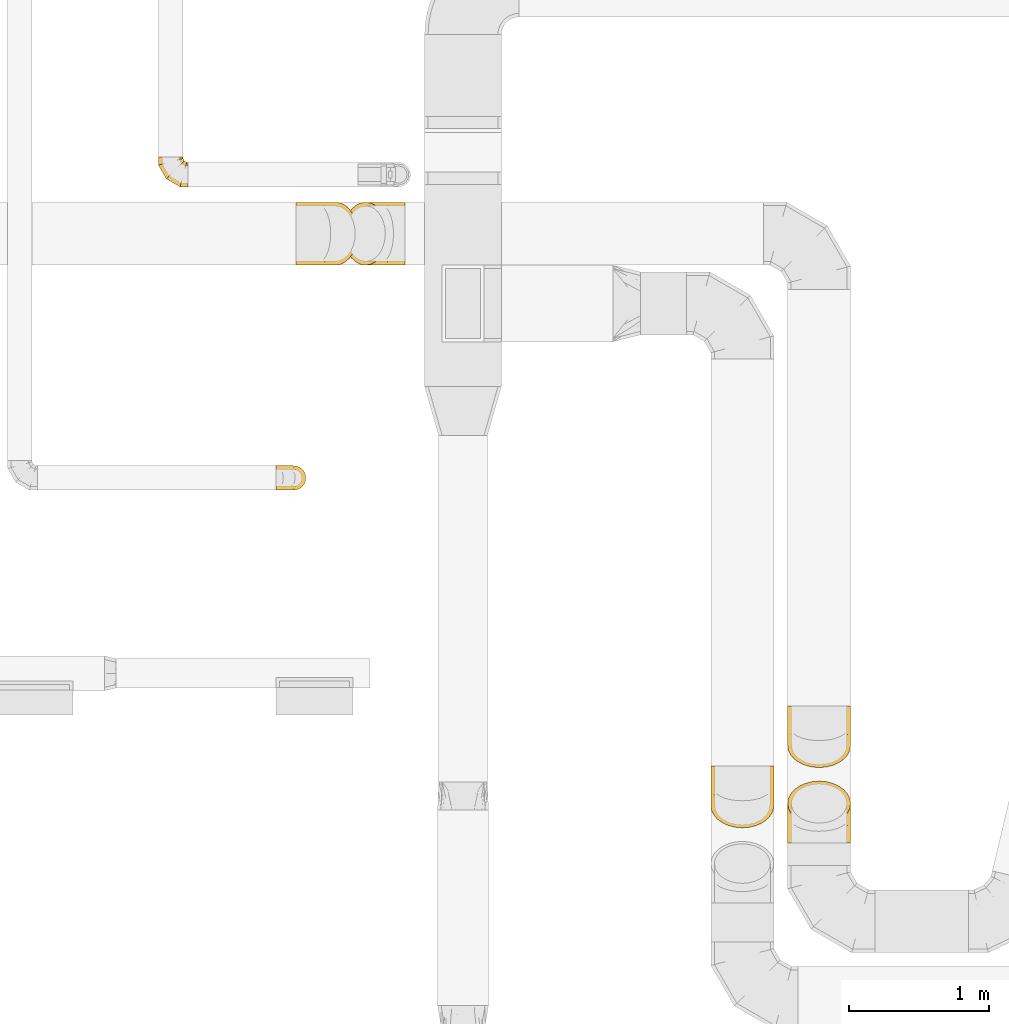
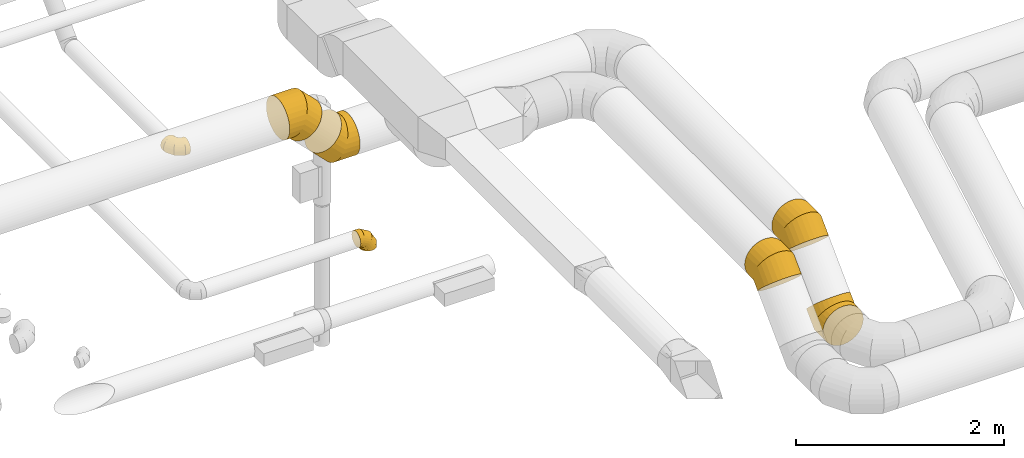
# One storey, part 15 of 97: 7 coverings.
"""IFC2X3 building model written with IfcOpenShell, lengths in millimetres."""

import ifcopenshell
import ifcopenshell.guid

model = None  # the IFC model being written
_history = None  # IfcOwnerHistory: only IFC2X3 demands one
_inside = {}  # id of a spatial element -> (the spatial element, [elements in it])
_under = {}  # id of a project, library or spatial element -> (it, [spatial elements below it])
_declared = {}  # id of a project -> (the project, [libraries it declares])
_typed = {}  # id of a type object -> (the type object, [elements of that type])
_made_of = {}  # id of a material, layer set ... -> (it, [elements and type objects made of it])


def new_model(schema):
    """Start an empty IFC model of exactly this schema.

    Asked for "IFC4X3", IfcOpenShell would pick the latest addendum, in which some entities
    have other attributes; the version numbers below select the first issue.
    IFC2X3 requires an IfcOwnerHistory on every rooted entity: one is made here for all.
    """
    global model, _history
    if schema == "IFC4X3":
        model = ifcopenshell.file(schema_version=(4, 3, 0, 0))
    else:
        model = ifcopenshell.file(schema=schema)
    _inside.clear()
    _under.clear()
    _declared.clear()
    _typed.clear()
    _made_of.clear()
    _history = None
    if model.schema == "IFC2X3":
        org = make("IfcOrganization", Name="unknown")
        user = make(
            "IfcPersonAndOrganization",
            ThePerson=make("IfcPerson", FamilyName="unknown"),
            TheOrganization=org,
        )
        app = make(
            "IfcApplication",
            ApplicationDeveloper=org,
            Version="unknown",
            ApplicationFullName="unknown",
            ApplicationIdentifier="unknown",
        )
        _history = make(
            "IfcOwnerHistory",
            OwningUser=user,
            OwningApplication=app,
            ChangeAction="ADDED",
            CreationDate=0,
        )
    return model


def make(cls, **values):
    """One entity of the class cls with the attributes given. An attribute that is None is left unset."""
    return model.create_entity(
        cls, **{name: value for name, value in values.items() if value is not None}
    )


def entity(cls, *values):
    """Any entity or typed value of the class cls, its attributes in the order of the schema. None: left unset."""
    e = model.create_entity(cls)
    for i, value in enumerate(values):
        if value is not None:
            e[i] = value
    return e


def rooted(cls, **values):
    """An entity with a GlobalId (a new one), such as an element, a storey or a relation."""
    return make(cls, GlobalId=ifcopenshell.guid.new(), OwnerHistory=_history, **values)


def si_unit(unit_type, name, prefix=None):
    """IfcSIUnit, for example si_unit("LENGTHUNIT", "METRE", prefix="MILLI")."""
    return make("IfcSIUnit", UnitType=unit_type, Prefix=prefix, Name=name)


def converted_unit(unit_type, name, factor, base, dimensions=None, offset=None):
    """IfcConversionBasedUnit, such as the inch: factor (a typed value) times the base unit."""
    return make(
        "IfcConversionBasedUnit"
        if offset is None
        else "IfcConversionBasedUnitWithOffset",
        ConversionOffset=offset,
        Dimensions=None
        if dimensions is None
        else entity("IfcDimensionalExponents", *dimensions),
        UnitType=unit_type,
        Name=name,
        ConversionFactor=make(
            "IfcMeasureWithUnit", ValueComponent=factor, UnitComponent=base
        ),
    )


def derived_unit(unit_type, elements):
    """IfcDerivedUnit: a product of units, each with its exponent."""
    return make(
        "IfcDerivedUnit",
        Elements=[
            make("IfcDerivedUnitElement", Unit=unit, Exponent=power)
            for unit, power in elements
        ],
        UnitType=unit_type,
    )


def assignment(units):
    """IfcUnitAssignment: the units of a project."""
    return None if units is None else make("IfcUnitAssignment", Units=units)


def point(xyz):
    """IfcCartesianPoint."""
    return None if xyz is None else make("IfcCartesianPoint", Coordinates=xyz)


def direction(xyz):
    """IfcDirection."""
    return None if xyz is None else make("IfcDirection", DirectionRatios=xyz)


def frame(location, z_axis=None, x_axis=None):
    """IfcAxis2Placement3D, a coordinate frame: its origin and axes. An axis left out is left unset."""
    return make(
        "IfcAxis2Placement3D",
        Location=point(location),
        Axis=direction(z_axis),
        RefDirection=direction(x_axis),
    )


def origin():
    """The frame at (0, 0, 0) with its axes left unset."""
    return frame((0.0, 0.0, 0.0))


def place(relative_to, where):
    """IfcLocalPlacement: puts the frame where relative to a parent placement (None: the world)."""
    return make(
        "IfcLocalPlacement", PlacementRelTo=relative_to, RelativePlacement=where
    )


def context(
    kind, dimensions, precision=None, world=None, true_north=None, identifier=None
):
    """IfcGeometricRepresentationContext, for example the 3D "Model" context."""
    return make(
        "IfcGeometricRepresentationContext",
        ContextIdentifier=identifier,
        ContextType=kind,
        CoordinateSpaceDimension=dimensions,
        Precision=precision,
        WorldCoordinateSystem=world,
        TrueNorth=true_north,
    )


def subcontext(parent, identifier, kind, view, scale=None):
    """IfcGeometricRepresentationSubContext, for example "Body" below "Model"."""
    return make(
        "IfcGeometricRepresentationSubContext",
        ContextIdentifier=identifier,
        ContextType=kind,
        ParentContext=parent,
        TargetScale=scale,
        TargetView=view,
    )


def project(units=None, contexts=None):
    """IfcProject with its units and contexts."""
    return rooted(
        "IfcProject",
        Name="project",
        RepresentationContexts=contexts,
        UnitsInContext=assignment(units),
    )


def spatial(cls, under=None, at=None, **own):
    """A site, building, storey or space (cls), placed at a placement, below another one or the project."""
    s = rooted(cls, ObjectPlacement=at, **own)
    if under is not None:
        _under.setdefault(under.id(), (under, []))[1].append(s)
    return s


def faces_of(points, faces, orient=None, outer=None):
    """IfcFace entities. A face is a list of loops; a loop is a list of indices into points, from 0.

    orient and outer hold one flag for each loop. By default every Orientation is true, the
    first loop of a face is its IfcFaceOuterBound and the others are IfcFaceBound.
    """
    made = []
    for i, loops in enumerate(faces):
        bounds = []
        for j, loop in enumerate(loops):
            is_outer = j == 0 if outer is None else outer[i][j]
            bounds.append(
                make(
                    "IfcFaceOuterBound" if is_outer else "IfcFaceBound",
                    Bound=make("IfcPolyLoop", Polygon=[points[k] for k in loop]),
                    Orientation=True if orient is None else orient[i][j],
                )
            )
        made.append(make("IfcFace", Bounds=bounds))
    return made


def faceted_brep(points, faces, orient=None, outer=None, voids=None):
    """IfcFacetedBrep: a solid bounded by flat faces; with voids (closed shells), ...WithVoids."""
    shared = [point(p) for p in points]
    hull = make("IfcClosedShell", CfsFaces=faces_of(shared, faces, orient, outer))
    if voids is None:
        return make("IfcFacetedBrep", Outer=hull)
    return make(
        "IfcFacetedBrepWithVoids",
        Outer=hull,
        Voids=[
            make(cls, CfsFaces=faces_of(shared, fs, o, b)) for cls, fs, o, b in voids
        ],
    )


def shape(context_of_items, identifier, shape_type, items):
    """IfcShapeRepresentation: the items that make up one representation, for example the "Body"."""
    return make(
        "IfcShapeRepresentation",
        ContextOfItems=context_of_items,
        RepresentationIdentifier=identifier,
        RepresentationType=shape_type,
        Items=items,
    )


def made_of(thing, what):
    """Note that an element or type object is made of a material, layer set ...; save() writes the relation."""
    if what is not None:
        _made_of.setdefault(what.id(), (what, []))[1].append(thing)
    return thing


def element(
    cls,
    number,
    at=None,
    inside=None,
    cuts=None,
    type_object=None,
    material=None,
    context=None,
    identifier="Body",
    shape_type=None,
    held_by="IfcProductDefinitionShape",
    body=None,
    shapes=None,
    **own,
):
    """One element of the class cls, such as IfcWall. Its Tag is "e" and its number.

    at: its placement. inside: the storey or other place that contains it. cuts: it is an
    opening in that element (IfcRelVoidsElement). A single representation is given by context,
    identifier, shape_type and body (its items); several are given by shapes. held_by: the class
    of the entity that holds the representations. save() writes the other relations.
    """
    e = rooted(cls, Tag="e%d" % number, ObjectPlacement=at, **own)
    if body is not None:
        shapes = [shape(context, identifier, shape_type, body)]
    if shapes is not None:
        e.Representation = make(held_by, Representations=shapes)
    if inside is not None:
        _inside.setdefault(inside.id(), (inside, []))[1].append(e)
    if cuts is not None:
        rooted(
            "IfcRelVoidsElement", RelatingBuildingElement=cuts, RelatedOpeningElement=e
        )
    if type_object is not None:
        _typed.setdefault(type_object.id(), (type_object, []))[1].append(e)
    return made_of(e, material)


def aggregate(whole, parts):
    """IfcRelAggregates: a whole, such as a stair, and the parts it consists of."""
    return rooted("IfcRelAggregates", RelatingObject=whole, RelatedObjects=parts)


def save(model, path):
    """Write the relations noted so far, then the file.

    IfcRelAggregates (storeys below a building ...), IfcRelContainedInSpatialStructure (elements
    in a storey), IfcRelDefinesByType, IfcRelAssociatesMaterial and IfcRelDeclares: one each for
    every whole, place, type object, material and project.
    """
    for whole, parts in _under.values():
        aggregate(whole, parts)
    for where, things in _inside.values():
        rooted(
            "IfcRelContainedInSpatialStructure",
            RelatedElements=things,
            RelatingStructure=where,
        )
    for kind, things in _typed.values():
        rooted("IfcRelDefinesByType", RelatedObjects=things, RelatingType=kind)
    for what, things in _made_of.values():
        rooted("IfcRelAssociatesMaterial", RelatedObjects=things, RelatingMaterial=what)
    for by, libraries in _declared.values():
        rooted("IfcRelDeclares", RelatingContext=by, RelatedDefinitions=libraries)
    model.write(path)


model = new_model("IFC2X3")

# Units and contexts
model_context = context("Model", 3, precision=0.01, world=origin(), true_north=direction((6.12303176911189e-17, 1.0)))
body_context = subcontext(model_context, "Body", "Model", "MODEL_VIEW")
ifc_project = project(units=[si_unit("LENGTHUNIT", "METRE", prefix="MILLI"), si_unit("AREAUNIT", "SQUARE_METRE"), si_unit("VOLUMEUNIT", "CUBIC_METRE"), converted_unit("PLANEANGLEUNIT", "DEGREE", entity("IfcRatioMeasure", 0.0174532925199433), si_unit("PLANEANGLEUNIT", "RADIAN"), dimensions=[0, 0, 0, 0, 0, 0, 0]), si_unit("MASSUNIT", "GRAM", prefix="KILO"), derived_unit("MASSDENSITYUNIT", [(si_unit("MASSUNIT", "GRAM", prefix="KILO"), 1), (si_unit("LENGTHUNIT", "METRE"), -3)]), derived_unit("MOMENTOFINERTIAUNIT", [(si_unit("LENGTHUNIT", "METRE"), 4)]), si_unit("TIMEUNIT", "SECOND"), si_unit("FREQUENCYUNIT", "HERTZ"), si_unit("THERMODYNAMICTEMPERATUREUNIT", "DEGREE_CELSIUS"), derived_unit("THERMALTRANSMITTANCEUNIT", [(si_unit("MASSUNIT", "GRAM", prefix="KILO"), 1), (si_unit("THERMODYNAMICTEMPERATUREUNIT", "KELVIN"), -1), (si_unit("TIMEUNIT", "SECOND"), -3)]), derived_unit("VOLUMETRICFLOWRATEUNIT", [(si_unit("LENGTHUNIT", "METRE"), 3), (si_unit("TIMEUNIT", "SECOND"), -1)]), derived_unit("MASSFLOWRATEUNIT", [(si_unit("MASSUNIT", "GRAM", prefix="KILO"), 1), (si_unit("TIMEUNIT", "SECOND"), -1)]), derived_unit("ROTATIONALFREQUENCYUNIT", [(si_unit("TIMEUNIT", "SECOND"), -1)]), si_unit("ELECTRICCURRENTUNIT", "AMPERE"), si_unit("ELECTRICVOLTAGEUNIT", "VOLT"), si_unit("POWERUNIT", "WATT"), si_unit("FORCEUNIT", "NEWTON", prefix="KILO"), si_unit("ILLUMINANCEUNIT", "LUX"), si_unit("LUMINOUSFLUXUNIT", "LUMEN"), si_unit("LUMINOUSINTENSITYUNIT", "CANDELA"), derived_unit("USERDEFINED", [(si_unit("MASSUNIT", "GRAM", prefix="KILO"), -1), (si_unit("LENGTHUNIT", "METRE"), -2), (si_unit("TIMEUNIT", "SECOND"), 3), (si_unit("LUMINOUSFLUXUNIT", "LUMEN"), 1)]), derived_unit("LINEARVELOCITYUNIT", [(si_unit("LENGTHUNIT", "METRE"), 1), (si_unit("TIMEUNIT", "SECOND"), -1)]), si_unit("PRESSUREUNIT", "PASCAL"), derived_unit("USERDEFINED", [(si_unit("LENGTHUNIT", "METRE"), -2), (si_unit("MASSUNIT", "GRAM", prefix="KILO"), 1), (si_unit("TIMEUNIT", "SECOND"), -2)]), derived_unit("LINEARFORCEUNIT", [(si_unit("MASSUNIT", "GRAM", prefix="KILO"), 1), (si_unit("LENGTHUNIT", "METRE"), 1), (si_unit("TIMEUNIT", "SECOND"), -2), (si_unit("LENGTHUNIT", "METRE"), -1)]), derived_unit("PLANARFORCEUNIT", [(si_unit("MASSUNIT", "GRAM", prefix="KILO"), 1), (si_unit("LENGTHUNIT", "METRE"), 1), (si_unit("TIMEUNIT", "SECOND"), -2), (si_unit("LENGTHUNIT", "METRE"), -2)])], contexts=[model_context])

# Site, building, storey
site_placement = place(None, origin())
site = spatial("IfcSite", under=ifc_project, at=site_placement, CompositionType="ELEMENT")
building_placement = place(site_placement, origin())
building = spatial("IfcBuilding", under=site, at=building_placement, CompositionType="ELEMENT")
storey_placement = place(building_placement, frame((0.0, 0.0, -4900.0)))
storey = spatial("IfcBuildingStorey", under=building, at=storey_placement, CompositionType="ELEMENT", Elevation=-4900.0)

# Coverings
covering_1_placement = place(storey_placement, frame((51787.5, 2897.28, 3322.15)))
element("IfcCovering", 1, at=covering_1_placement, inside=storey, PredefinedType="INSULATION", context=body_context, shape_type="Brep", body=[
    faceted_brep([(226.6, 319.79, 1.6), (276.66, 315.8, 5.58), (324.22, 304.04, 17.35), (366.88, 285.08, 36.31), (402.51, 259.89, 61.5), (429.31, 229.72, 91.66), (445.95, 196.1, 125.29), (451.6, 160.69, 160.69), (445.95, 125.29, 196.1), (429.31, 91.66, 229.72), (402.51, 61.5, 259.89), (366.88, 36.31, 285.08), (324.22, 17.35, 304.04), (276.66, 5.58, 315.8), (226.6, 1.6, 319.79), (176.53, 5.58, 315.8), (128.97, 17.35, 304.04), (86.31, 36.31, 285.08), (50.68, 61.5, 259.89), (23.88, 91.66, 229.72), (7.24, 125.29, 196.1), (1.6, 160.69, 160.69), (7.24, 196.1, 125.29), (23.88, 229.72, 91.66), (50.68, 259.89, 61.5), (86.31, 285.08, 36.31), (128.97, 304.04, 17.35), (176.53, 315.8, 5.58), (86.31, 443.54, 453.76), (128.97, 443.54, 480.57), (176.53, 443.54, 497.21), (226.6, 443.54, 502.85), (276.66, 443.54, 497.21), (324.22, 443.54, 480.57), (366.88, 443.54, 453.76), (402.51, 443.54, 418.14), (429.31, 443.54, 375.48), (445.95, 443.54, 327.92), (451.6, 443.54, 277.85), (445.95, 443.54, 227.78), (429.31, 443.54, 180.23), (402.51, 443.54, 137.57), (366.88, 443.54, 101.94), (324.22, 443.54, 75.13), (276.66, 443.54, 58.49), (226.6, 443.54, 52.85), (176.53, 443.54, 58.49), (128.97, 443.54, 75.13), (86.31, 443.54, 101.94), (50.68, 443.54, 137.57), (23.88, 443.54, 180.23), (7.24, 443.54, 227.78), (1.6, 443.54, 277.85), (7.24, 443.54, 327.92), (23.88, 443.54, 375.48), (50.68, 443.54, 418.14), (226.6, 184.65, 502.85), (276.66, 186.99, 497.21), (324.22, 193.88, 480.57), (366.88, 204.99, 453.76), (402.51, 219.74, 418.14), (429.31, 237.41, 375.48), (445.95, 257.11, 327.92), (451.6, 277.85, 277.85), (445.95, 298.59, 227.78), (429.31, 318.29, 180.23), (402.51, 335.96, 137.57), (366.88, 350.72, 101.94), (324.22, 361.82, 75.13), (276.66, 368.71, 58.49), (226.6, 371.05, 52.85), (176.53, 368.71, 58.49), (128.97, 361.82, 75.13), (86.31, 350.72, 101.94), (50.68, 335.96, 137.57), (23.88, 318.29, 180.23), (7.24, 298.59, 227.78), (1.6, 277.85, 277.85), (7.24, 257.11, 327.92), (23.88, 237.41, 375.48), (50.68, 219.74, 418.14), (86.31, 204.99, 453.76), (128.97, 193.88, 480.57), (176.53, 186.99, 497.21)], [[[0, 1, 2, 3, 4, 5, 6, 7, 8, 9, 10, 11, 12, 13, 14, 15, 16, 17, 18, 19, 20, 21, 22, 23, 24, 25, 26, 27]], [[28, 29, 30, 31, 32, 33, 34, 35, 36, 37, 38, 39, 40, 41, 42, 43, 44, 45, 46, 47, 48, 49, 50, 51, 52, 53, 54, 55]], [[31, 56, 57, 32]], [[32, 57, 58, 33]], [[33, 58, 59, 34]], [[59, 60, 35, 34]], [[35, 60, 61, 36]], [[36, 61, 62, 37]], [[37, 62, 63, 38]], [[63, 64, 39, 38]], [[65, 66, 41, 40]], [[64, 65, 40, 39]], [[66, 67, 42, 41]], [[67, 68, 43, 42]], [[69, 70, 45, 44]], [[68, 69, 44, 43]], [[70, 71, 46, 45]], [[72, 73, 48, 47]], [[71, 72, 47, 46]], [[73, 74, 49, 48]], [[74, 75, 50, 49]], [[76, 77, 52, 51]], [[75, 76, 51, 50]], [[53, 52, 77, 78]], [[78, 79, 54, 53]], [[80, 55, 54, 79]], [[80, 81, 28, 55]], [[29, 28, 81, 82]], [[82, 83, 30, 29]], [[56, 31, 30, 83]], [[14, 13, 57, 56]], [[12, 11, 59, 58]], [[13, 12, 58, 57]], [[11, 10, 60, 59]], [[61, 60, 10, 9]], [[62, 61, 9, 8]], [[63, 62, 8, 7]], [[64, 63, 7, 6]], [[65, 64, 6, 5]], [[66, 65, 5, 4]], [[4, 3, 67, 66]], [[68, 67, 3, 2]], [[69, 68, 2, 1]], [[70, 69, 1, 0]], [[70, 0, 27, 71]], [[71, 27, 26, 72]], [[72, 26, 25, 73]], [[25, 24, 74, 73]], [[74, 24, 23, 75]], [[75, 23, 22, 76]], [[76, 22, 21, 77]], [[77, 21, 20, 78]], [[78, 20, 19, 79]], [[79, 19, 18, 80]], [[18, 17, 81, 80]], [[81, 17, 16, 82]], [[82, 16, 15, 83]], [[83, 15, 14, 56]]]),
])
covering_2_placement = place(storey_placement, frame((51787.5, 2359.45, 2723.4)))
element("IfcCovering", 2, at=covering_2_placement, inside=storey, PredefinedType="INSULATION", context=body_context, shape_type="Brep", body=[
    faceted_brep([(176.53, 0.0, 445.95), (128.97, 0.0, 429.31), (86.31, 0.0, 402.51), (50.68, 0.0, 366.88), (23.88, 0.0, 324.22), (7.24, 0.0, 276.66), (1.6, 0.0, 226.6), (7.24, 0.0, 176.53), (23.88, 0.0, 128.97), (50.68, 0.0, 86.31), (86.31, 0.0, 50.68), (128.97, 0.0, 23.88), (176.53, 0.0, 7.24), (226.6, 0.0, 1.6), (276.66, 0.0, 7.24), (324.22, 0.0, 23.88), (366.88, 0.0, 50.68), (402.51, 0.0, 86.31), (429.31, 0.0, 128.97), (445.95, 0.0, 176.53), (451.6, 0.0, 226.6), (445.95, 0.0, 276.66), (429.31, 0.0, 324.22), (402.51, 0.0, 366.88), (366.88, 0.0, 402.51), (324.22, 0.0, 429.31), (276.66, 0.0, 445.95), (226.6, 0.0, 451.6), (366.88, 407.23, 219.36), (324.22, 426.19, 200.41), (276.66, 437.95, 188.64), (226.6, 441.94, 184.65), (176.53, 437.95, 188.64), (128.97, 426.19, 200.41), (86.31, 407.23, 219.36), (50.68, 382.04, 244.56), (23.88, 351.87, 274.72), (7.24, 318.25, 308.35), (1.6, 282.84, 343.75), (7.24, 247.44, 379.16), (23.88, 213.81, 412.78), (50.68, 183.65, 442.95), (86.31, 158.45, 468.14), (128.97, 139.5, 487.1), (176.53, 127.73, 498.86), (226.6, 123.74, 502.85), (276.66, 127.73, 498.86), (324.22, 139.5, 487.1), (366.88, 158.45, 468.14), (402.51, 183.65, 442.95), (429.31, 213.81, 412.78), (445.95, 247.44, 379.16), (451.6, 282.84, 343.75), (445.95, 318.25, 308.35), (429.31, 351.87, 274.72), (402.51, 382.04, 244.56), (226.6, 258.88, 1.6), (176.53, 256.55, 7.24), (128.97, 249.65, 23.88), (86.31, 238.55, 50.68), (50.68, 223.79, 86.31), (23.88, 206.12, 128.97), (7.24, 186.42, 176.53), (1.6, 165.69, 226.6), (7.24, 144.95, 276.66), (23.88, 125.25, 324.22), (50.68, 107.58, 366.88), (86.31, 92.82, 402.51), (128.97, 81.72, 429.31), (176.53, 74.82, 445.95), (226.6, 72.49, 451.6), (276.66, 74.82, 445.95), (324.22, 81.72, 429.31), (366.88, 92.82, 402.51), (402.51, 107.58, 366.88), (429.31, 125.25, 324.22), (445.95, 144.95, 276.66), (451.6, 165.69, 226.6), (445.95, 186.42, 176.53), (429.31, 206.12, 128.97), (402.51, 223.79, 86.31), (366.88, 238.55, 50.68), (324.22, 249.65, 23.88), (276.66, 256.55, 7.24)], [[[0, 1, 2, 3, 4, 5, 6, 7, 8, 9, 10, 11, 12, 13, 14, 15, 16, 17, 18, 19, 20, 21, 22, 23, 24, 25, 26, 27]], [[28, 29, 30, 31, 32, 33, 34, 35, 36, 37, 38, 39, 40, 41, 42, 43, 44, 45, 46, 47, 48, 49, 50, 51, 52, 53, 54, 55]], [[31, 56, 57, 32]], [[32, 57, 58, 33]], [[33, 58, 59, 34]], [[59, 60, 35, 34]], [[35, 60, 61, 36]], [[36, 61, 62, 37]], [[37, 62, 63, 38]], [[63, 64, 39, 38]], [[65, 66, 41, 40]], [[64, 65, 40, 39]], [[66, 67, 42, 41]], [[67, 68, 43, 42]], [[69, 70, 45, 44]], [[68, 69, 44, 43]], [[70, 71, 46, 45]], [[72, 73, 48, 47]], [[71, 72, 47, 46]], [[73, 74, 49, 48]], [[74, 75, 50, 49]], [[76, 77, 52, 51]], [[75, 76, 51, 50]], [[53, 52, 77, 78]], [[78, 79, 54, 53]], [[80, 55, 54, 79]], [[80, 81, 28, 55]], [[29, 28, 81, 82]], [[82, 83, 30, 29]], [[56, 31, 30, 83]], [[13, 12, 57, 56]], [[11, 10, 59, 58]], [[12, 11, 58, 57]], [[10, 9, 60, 59]], [[61, 60, 9, 8]], [[62, 61, 8, 7]], [[63, 62, 7, 6]], [[64, 63, 6, 5]], [[65, 64, 5, 4]], [[66, 65, 4, 3]], [[3, 2, 67, 66]], [[68, 67, 2, 1]], [[69, 68, 1, 0]], [[70, 69, 0, 27]], [[70, 27, 26, 71]], [[71, 26, 25, 72]], [[72, 25, 24, 73]], [[24, 23, 74, 73]], [[74, 23, 22, 75]], [[75, 22, 21, 76]], [[76, 21, 20, 77]], [[77, 20, 19, 78]], [[78, 19, 18, 79]], [[79, 18, 17, 80]], [[17, 16, 81, 80]], [[81, 16, 15, 82]], [[82, 15, 14, 83]], [[83, 14, 13, 56]]]),
])
covering_3_placement = place(storey_placement, frame((48124.39, 4884.24, 3615.0)))
element("IfcCovering", 3, at=covering_3_placement, inside=storey, PredefinedType="INSULATION", context=body_context, shape_type="Brep", body=[
    faceted_brep([(0.0, 1.6, 125.0), (0.0, 5.88, 152.04), (0.0, 18.31, 176.43), (0.0, 37.66, 195.79), (0.0, 62.06, 208.22), (0.0, 89.1, 212.5), (0.0, 116.13, 208.22), (0.0, 140.53, 195.79), (0.0, 159.88, 176.43), (0.0, 172.31, 152.04), (0.0, 176.6, 125.0), (0.0, 172.31, 97.96), (0.0, 159.88, 73.57), (0.0, 140.53, 54.21), (0.0, 128.33, 48.0), (0.0, 116.13, 41.78), (0.0, 102.61, 39.64), (0.0, 89.1, 37.5), (0.0, 75.58, 39.64), (0.0, 62.06, 41.78), (0.0, 49.86, 48.0), (0.0, 37.66, 54.21), (0.0, 18.31, 73.57), (0.0, 5.88, 97.96), (200.78, 132.85, 0.0), (209.52, 111.74, 0.0), (212.5, 89.1, 0.0), (209.52, 66.45, 0.0), (200.78, 45.35, 0.0), (186.87, 27.22, 0.0), (168.75, 13.32, 0.0), (147.65, 4.58, 0.0), (125.0, 1.6, 0.0), (102.35, 4.58, 0.0), (81.25, 13.32, 0.0), (63.13, 27.22, 0.0), (49.22, 45.35, 0.0), (40.48, 66.45, 0.0), (37.5, 89.1, 0.0), (40.48, 111.74, 0.0), (49.22, 132.85, 0.0), (63.13, 150.97, 0.0), (81.25, 164.87, 0.0), (102.35, 173.61, 0.0), (125.0, 176.6, 0.0), (147.65, 173.61, 0.0), (168.75, 164.87, 0.0), (186.87, 150.97, 0.0), (212.5, 89.1, 56.94), (209.52, 66.45, 56.14), (200.78, 45.35, 53.8), (186.87, 27.22, 50.07), (168.75, 13.32, 45.22), (147.65, 4.58, 39.56), (125.0, 1.6, 33.49), (102.35, 4.58, 27.43), (81.25, 13.32, 21.77), (63.13, 27.22, 16.92), (49.22, 45.35, 13.19), (40.48, 66.45, 10.85), (37.5, 89.1, 10.05), (40.48, 111.74, 10.85), (49.22, 132.85, 13.19), (63.13, 150.97, 16.92), (102.35, 173.61, 27.43), (125.0, 176.6, 33.49), (81.25, 164.87, 21.77), (147.65, 173.61, 39.56), (168.75, 164.87, 45.22), (186.87, 150.97, 50.07), (200.78, 132.85, 53.8), (209.52, 111.74, 56.14), (155.56, 89.1, 155.56), (153.38, 66.45, 153.38), (146.98, 45.35, 146.98), (136.8, 27.22, 136.8), (123.53, 13.32, 123.53), (108.08, 4.58, 108.08), (91.51, 1.6, 91.51), (74.93, 4.58, 74.93), (59.48, 13.32, 59.48), (46.21, 27.22, 46.21), (36.03, 45.35, 36.03), (29.63, 66.45, 29.63), (27.45, 89.1, 27.45), (29.63, 111.74, 29.63), (36.03, 132.85, 36.03), (46.21, 150.97, 46.21), (74.93, 173.61, 74.93), (91.51, 176.6, 91.51), (59.48, 164.87, 59.48), (108.08, 173.61, 108.08), (123.53, 164.87, 123.53), (136.8, 150.97, 136.8), (146.98, 132.85, 146.98), (153.38, 111.74, 153.38), (56.94, 89.1, 212.5), (56.14, 66.45, 209.52), (53.8, 45.35, 200.78), (50.07, 27.22, 186.87), (45.22, 13.32, 168.75), (39.56, 4.58, 147.65), (33.49, 1.6, 125.0), (27.43, 4.58, 102.35), (21.77, 13.32, 81.25), (16.92, 27.22, 63.13), (13.19, 45.35, 49.22), (10.85, 66.45, 40.48), (10.45, 77.77, 38.99), (10.05, 89.1, 37.5), (10.85, 111.74, 40.48), (13.19, 132.85, 49.22), (10.45, 100.42, 38.99), (16.92, 150.97, 63.13), (27.43, 173.61, 102.35), (33.49, 176.6, 125.0), (21.77, 164.87, 81.25), (39.56, 173.61, 147.65), (45.22, 164.87, 168.75), (50.07, 150.97, 186.87), (53.8, 132.85, 200.78), (56.14, 111.74, 209.52)], [[[0, 1, 2, 3, 4, 5, 6, 7, 8, 9, 10, 11, 12, 13, 14, 15, 16, 17, 18, 19, 20, 21, 22, 23]], [[24, 25, 26, 27, 28, 29, 30, 31, 32, 33, 34, 35, 36, 37, 38, 39, 40, 41, 42, 43, 44, 45, 46, 47]], [[26, 48, 49, 27]], [[27, 49, 50, 28]], [[28, 50, 51, 29]], [[30, 52, 53, 31]], [[31, 53, 54, 32]], [[29, 51, 52, 30]], [[55, 56, 34, 33]], [[54, 55, 33, 32]], [[57, 35, 34, 56]], [[58, 59, 37, 36]], [[58, 36, 35, 57]], [[60, 38, 37, 59]], [[61, 62, 40, 39]], [[60, 61, 39, 38]], [[41, 40, 62, 63]], [[64, 65, 44, 43]], [[66, 64, 43, 42]], [[63, 66, 42, 41]], [[46, 45, 67, 68]], [[47, 46, 68, 69]], [[44, 65, 67, 45]], [[25, 24, 70, 71]], [[26, 25, 71, 48]], [[69, 70, 24, 47]], [[49, 48, 72, 73]], [[50, 49, 73, 74]], [[74, 75, 51, 50]], [[52, 51, 75, 76]], [[53, 52, 76, 77]], [[54, 53, 77, 78]], [[79, 80, 56, 55]], [[78, 79, 55, 54]], [[57, 56, 80, 81]], [[82, 83, 59, 58]], [[81, 82, 58, 57]], [[60, 59, 83, 84]], [[85, 86, 62, 61]], [[84, 85, 61, 60]], [[63, 62, 86, 87]], [[88, 89, 65, 64]], [[90, 88, 64, 66]], [[87, 90, 66, 63]], [[67, 65, 89, 91]], [[68, 67, 91, 92]], [[69, 68, 92, 93]], [[71, 70, 94, 95]], [[48, 71, 95, 72]], [[93, 94, 70, 69]], [[73, 72, 96, 97]], [[74, 73, 97, 98]], [[98, 99, 75, 74]], [[76, 75, 99, 100]], [[77, 76, 100, 101]], [[78, 77, 101, 102]], [[103, 104, 80, 79]], [[102, 103, 79, 78]], [[81, 80, 104, 105]], [[106, 107, 83, 82]], [[105, 106, 82, 81]], [[84, 83, 107, 108, 109]], [[110, 111, 86, 85]], [[85, 84, 109, 112, 110]], [[87, 86, 111, 113]], [[114, 115, 89, 88]], [[116, 114, 88, 90]], [[113, 116, 90, 87]], [[91, 89, 115, 117]], [[92, 91, 117, 118]], [[93, 92, 118, 119]], [[95, 94, 120, 121]], [[72, 95, 121, 96]], [[119, 120, 94, 93]], [[97, 5, 4]], [[98, 4, 3]], [[5, 97, 96]], [[97, 4, 98]], [[3, 99, 98]], [[100, 2, 1]], [[101, 1, 0]], [[99, 2, 100]], [[100, 1, 101]], [[0, 102, 101]], [[2, 99, 3]], [[103, 0, 23]], [[104, 23, 22]], [[103, 102, 0]], [[104, 103, 23]], [[22, 105, 104]], [[20, 19, 107]], [[17, 109, 108]], [[107, 19, 18]], [[106, 105, 21]], [[106, 21, 20]], [[107, 18, 108]], [[20, 107, 106]], [[17, 108, 18]], [[21, 105, 22]], [[110, 16, 15]], [[111, 14, 13]], [[17, 112, 109]], [[17, 16, 112]], [[110, 15, 14]], [[110, 14, 111]], [[13, 113, 111]], [[116, 12, 11]], [[114, 11, 10]], [[116, 113, 12]], [[115, 114, 10]], [[116, 11, 114]], [[16, 110, 112]], [[12, 113, 13]], [[117, 10, 9]], [[118, 9, 8]], [[10, 117, 115]], [[117, 9, 118]], [[8, 119, 118]], [[120, 7, 6]], [[121, 6, 5]], [[119, 7, 120]], [[121, 120, 6]], [[96, 121, 5]], [[7, 119, 8]]]),
])
covering_4_placement = place(storey_placement, frame((51237.56, 2465.7, 3322.15)))
element("IfcCovering", 4, at=covering_4_placement, inside=storey, PredefinedType="INSULATION", context=body_context, shape_type="Brep", body=[
    faceted_brep([(226.6, 319.79, 1.6), (276.66, 315.8, 5.58), (324.22, 304.04, 17.35), (366.88, 285.08, 36.31), (402.51, 259.89, 61.5), (429.31, 229.72, 91.66), (445.95, 196.1, 125.29), (451.6, 160.69, 160.69), (445.95, 125.29, 196.1), (429.31, 91.66, 229.72), (402.51, 61.5, 259.89), (366.88, 36.31, 285.08), (324.22, 17.35, 304.04), (276.66, 5.58, 315.8), (226.6, 1.6, 319.79), (176.53, 5.58, 315.8), (128.97, 17.35, 304.04), (86.31, 36.31, 285.08), (50.68, 61.5, 259.89), (23.88, 91.66, 229.72), (7.24, 125.29, 196.1), (1.6, 160.69, 160.69), (7.24, 196.1, 125.29), (23.88, 229.72, 91.66), (50.68, 259.89, 61.5), (86.31, 285.08, 36.31), (128.97, 304.04, 17.35), (176.53, 315.8, 5.58), (86.31, 443.54, 453.76), (128.97, 443.54, 480.57), (176.53, 443.54, 497.21), (226.6, 443.54, 502.85), (276.66, 443.54, 497.21), (324.22, 443.54, 480.57), (366.88, 443.54, 453.76), (402.51, 443.54, 418.14), (429.31, 443.54, 375.48), (445.95, 443.54, 327.92), (451.6, 443.54, 277.85), (445.95, 443.54, 227.78), (429.31, 443.54, 180.23), (402.51, 443.54, 137.57), (366.88, 443.54, 101.94), (324.22, 443.54, 75.13), (276.66, 443.54, 58.49), (226.6, 443.54, 52.85), (176.53, 443.54, 58.49), (128.97, 443.54, 75.13), (86.31, 443.54, 101.94), (50.68, 443.54, 137.57), (23.88, 443.54, 180.23), (7.24, 443.54, 227.78), (1.6, 443.54, 277.85), (7.24, 443.54, 327.92), (23.88, 443.54, 375.48), (50.68, 443.54, 418.14), (226.6, 184.65, 502.85), (276.66, 186.99, 497.21), (324.22, 193.88, 480.57), (366.88, 204.99, 453.76), (402.51, 219.74, 418.14), (429.31, 237.41, 375.48), (445.95, 257.11, 327.92), (451.6, 277.85, 277.85), (445.95, 298.59, 227.78), (429.31, 318.29, 180.23), (402.51, 335.96, 137.57), (366.88, 350.72, 101.94), (324.22, 361.82, 75.13), (276.66, 368.71, 58.49), (226.6, 371.05, 52.85), (176.53, 368.71, 58.49), (128.97, 361.82, 75.13), (86.31, 350.72, 101.94), (50.68, 335.96, 137.57), (23.88, 318.29, 180.23), (7.24, 298.59, 227.78), (1.6, 277.85, 277.85), (7.24, 257.11, 327.92), (23.88, 237.41, 375.48), (50.68, 219.74, 418.14), (86.31, 204.99, 453.76), (128.97, 193.88, 480.57), (176.53, 186.99, 497.21)], [[[0, 1, 2, 3, 4, 5, 6, 7, 8, 9, 10, 11, 12, 13, 14, 15, 16, 17, 18, 19, 20, 21, 22, 23, 24, 25, 26, 27]], [[28, 29, 30, 31, 32, 33, 34, 35, 36, 37, 38, 39, 40, 41, 42, 43, 44, 45, 46, 47, 48, 49, 50, 51, 52, 53, 54, 55]], [[31, 56, 57, 32]], [[32, 57, 58, 33]], [[33, 58, 59, 34]], [[59, 60, 35, 34]], [[35, 60, 61, 36]], [[36, 61, 62, 37]], [[37, 62, 63, 38]], [[63, 64, 39, 38]], [[65, 66, 41, 40]], [[64, 65, 40, 39]], [[66, 67, 42, 41]], [[67, 68, 43, 42]], [[69, 70, 45, 44]], [[68, 69, 44, 43]], [[70, 71, 46, 45]], [[72, 73, 48, 47]], [[71, 72, 47, 46]], [[73, 74, 49, 48]], [[74, 75, 50, 49]], [[76, 77, 52, 51]], [[75, 76, 51, 50]], [[53, 52, 77, 78]], [[78, 79, 54, 53]], [[80, 55, 54, 79]], [[80, 81, 28, 55]], [[29, 28, 81, 82]], [[82, 83, 30, 29]], [[56, 31, 30, 83]], [[14, 13, 57, 56]], [[12, 11, 59, 58]], [[13, 12, 58, 57]], [[11, 10, 60, 59]], [[61, 60, 10, 9]], [[62, 61, 9, 8]], [[63, 62, 8, 7]], [[64, 63, 7, 6]], [[65, 64, 6, 5]], [[66, 65, 5, 4]], [[4, 3, 67, 66]], [[68, 67, 3, 2]], [[69, 68, 2, 1]], [[70, 69, 1, 0]], [[70, 0, 27, 71]], [[71, 27, 26, 72]], [[72, 26, 25, 73]], [[25, 24, 74, 73]], [[74, 24, 23, 75]], [[75, 23, 22, 76]], [[76, 22, 21, 77]], [[77, 21, 20, 78]], [[78, 20, 19, 79]], [[79, 19, 18, 80]], [[18, 17, 81, 80]], [[81, 17, 16, 82]], [[82, 16, 15, 83]], [[83, 15, 14, 56]]]),
])
covering_5_placement = place(storey_placement, frame((48266.69, 6496.49, 3772.15)))
element("IfcCovering", 5, at=covering_5_placement, inside=storey, PredefinedType="INSULATION", context=body_context, shape_type="Brep", body=[
    faceted_brep([(123.74, 226.6, 1.6), (127.73, 276.66, 5.58), (139.5, 324.22, 17.35), (158.45, 366.88, 36.31), (183.65, 402.51, 61.5), (213.81, 429.31, 91.66), (247.44, 445.95, 125.29), (282.84, 451.6, 160.69), (318.25, 445.95, 196.1), (351.87, 429.31, 229.72), (382.04, 402.51, 259.89), (407.23, 366.88, 285.08), (426.19, 324.22, 304.04), (437.95, 276.66, 315.8), (441.94, 226.6, 319.79), (437.95, 176.53, 315.8), (426.19, 128.97, 304.04), (407.23, 86.31, 285.08), (382.04, 50.68, 259.89), (351.87, 23.88, 229.72), (318.25, 7.24, 196.1), (282.84, 1.6, 160.69), (247.44, 7.24, 125.29), (213.81, 23.88, 91.66), (183.65, 50.68, 61.5), (158.45, 86.31, 36.31), (139.5, 128.97, 17.35), (127.73, 176.53, 5.58), (0.0, 86.31, 453.76), (0.0, 128.97, 480.57), (0.0, 176.53, 497.21), (0.0, 226.6, 502.85), (0.0, 276.66, 497.21), (0.0, 324.22, 480.57), (0.0, 366.88, 453.76), (0.0, 402.51, 418.14), (0.0, 429.31, 375.48), (0.0, 445.95, 327.92), (0.0, 451.6, 277.85), (0.0, 445.95, 227.78), (0.0, 429.31, 180.23), (0.0, 402.51, 137.57), (0.0, 366.88, 101.94), (0.0, 324.22, 75.13), (0.0, 276.66, 58.49), (0.0, 226.6, 52.85), (0.0, 176.53, 58.49), (0.0, 128.97, 75.13), (0.0, 86.31, 101.94), (0.0, 50.68, 137.57), (0.0, 23.88, 180.23), (0.0, 7.24, 227.78), (0.0, 1.6, 277.85), (0.0, 7.24, 327.92), (0.0, 23.88, 375.48), (0.0, 50.68, 418.14), (258.88, 226.6, 502.85), (256.55, 276.66, 497.21), (249.65, 324.22, 480.57), (238.55, 366.88, 453.76), (223.79, 402.51, 418.14), (206.12, 429.31, 375.48), (186.42, 445.95, 327.92), (165.69, 451.6, 277.85), (144.95, 445.95, 227.78), (125.25, 429.31, 180.23), (107.58, 402.51, 137.57), (92.82, 366.88, 101.94), (81.72, 324.22, 75.13), (74.82, 276.66, 58.49), (72.49, 226.6, 52.85), (74.82, 176.53, 58.49), (81.72, 128.97, 75.13), (92.82, 86.31, 101.94), (107.58, 50.68, 137.57), (125.25, 23.88, 180.23), (144.95, 7.24, 227.78), (165.69, 1.6, 277.85), (186.42, 7.24, 327.92), (206.12, 23.88, 375.48), (223.79, 50.68, 418.14), (238.55, 86.31, 453.76), (249.65, 128.97, 480.57), (256.55, 176.53, 497.21)], [[[0, 1, 2, 3, 4, 5, 6, 7, 8, 9, 10, 11, 12, 13, 14, 15, 16, 17, 18, 19, 20, 21, 22, 23, 24, 25, 26, 27]], [[28, 29, 30, 31, 32, 33, 34, 35, 36, 37, 38, 39, 40, 41, 42, 43, 44, 45, 46, 47, 48, 49, 50, 51, 52, 53, 54, 55]], [[31, 56, 57, 32]], [[32, 57, 58, 33]], [[33, 58, 59, 34]], [[59, 60, 35, 34]], [[35, 60, 61, 36]], [[36, 61, 62, 37]], [[37, 62, 63, 38]], [[63, 64, 39, 38]], [[65, 66, 41, 40]], [[64, 65, 40, 39]], [[66, 67, 42, 41]], [[67, 68, 43, 42]], [[69, 70, 45, 44]], [[68, 69, 44, 43]], [[70, 71, 46, 45]], [[72, 73, 48, 47]], [[71, 72, 47, 46]], [[73, 74, 49, 48]], [[74, 75, 50, 49]], [[76, 77, 52, 51]], [[75, 76, 51, 50]], [[53, 52, 77, 78]], [[78, 79, 54, 53]], [[80, 55, 54, 79]], [[80, 81, 28, 55]], [[29, 28, 81, 82]], [[82, 83, 30, 29]], [[56, 31, 30, 83]], [[14, 13, 57, 56]], [[12, 11, 59, 58]], [[13, 12, 58, 57]], [[11, 10, 60, 59]], [[61, 60, 10, 9]], [[62, 61, 9, 8]], [[63, 62, 8, 7]], [[64, 63, 7, 6]], [[65, 64, 6, 5]], [[66, 65, 5, 4]], [[4, 3, 67, 66]], [[68, 67, 3, 2]], [[69, 68, 2, 1]], [[70, 69, 1, 0]], [[70, 0, 27, 71]], [[71, 27, 26, 72]], [[72, 26, 25, 73]], [[25, 24, 74, 73]], [[74, 24, 23, 75]], [[75, 23, 22, 76]], [[76, 22, 21, 77]], [[77, 21, 20, 78]], [[78, 20, 19, 79]], [[79, 19, 18, 80]], [[18, 17, 81, 80]], [[81, 17, 16, 82]], [[82, 16, 15, 83]], [[83, 15, 14, 56]]]),
])
covering_6_placement = place(storey_placement, frame((48604.53, 6496.49, 3373.4)))
element("IfcCovering", 6, at=covering_6_placement, inside=storey, PredefinedType="INSULATION", context=body_context, shape_type="Brep", body=[
    faceted_brep([(443.54, 176.53, 445.95), (443.54, 128.97, 429.31), (443.54, 86.31, 402.51), (443.54, 50.68, 366.88), (443.54, 23.88, 324.22), (443.54, 7.24, 276.66), (443.54, 1.6, 226.6), (443.54, 7.24, 176.53), (443.54, 23.88, 128.97), (443.54, 50.68, 86.31), (443.54, 86.31, 50.68), (443.54, 128.97, 23.88), (443.54, 176.53, 7.24), (443.54, 226.6, 1.6), (443.54, 276.66, 7.24), (443.54, 324.22, 23.88), (443.54, 366.88, 50.68), (443.54, 402.51, 86.31), (443.54, 429.31, 128.97), (443.54, 445.95, 176.53), (443.54, 451.6, 226.6), (443.54, 445.95, 276.66), (443.54, 429.31, 324.22), (443.54, 402.51, 366.88), (443.54, 366.88, 402.51), (443.54, 324.22, 429.31), (443.54, 276.66, 445.95), (443.54, 226.6, 451.6), (36.31, 366.88, 219.36), (17.35, 324.22, 200.41), (5.58, 276.66, 188.64), (1.6, 226.6, 184.65), (5.58, 176.53, 188.64), (17.35, 128.97, 200.41), (36.31, 86.31, 219.36), (61.5, 50.68, 244.56), (91.66, 23.88, 274.72), (125.29, 7.24, 308.35), (160.69, 1.6, 343.75), (196.1, 7.24, 379.16), (229.72, 23.88, 412.78), (259.89, 50.68, 442.95), (285.08, 86.31, 468.14), (304.04, 128.97, 487.1), (315.8, 176.53, 498.86), (319.79, 226.6, 502.85), (315.8, 276.66, 498.86), (304.04, 324.22, 487.1), (285.08, 366.88, 468.14), (259.89, 402.51, 442.95), (229.72, 429.31, 412.78), (196.1, 445.95, 379.16), (160.69, 451.6, 343.75), (125.29, 445.95, 308.35), (91.66, 429.31, 274.72), (61.5, 402.51, 244.56), (184.65, 226.6, 1.6), (186.99, 176.53, 7.24), (193.88, 128.97, 23.88), (204.99, 86.31, 50.68), (219.74, 50.68, 86.31), (237.41, 23.88, 128.97), (257.11, 7.24, 176.53), (277.85, 1.6, 226.6), (298.59, 7.24, 276.66), (318.29, 23.88, 324.22), (335.96, 50.68, 366.88), (350.72, 86.31, 402.51), (361.82, 128.97, 429.31), (368.71, 176.53, 445.95), (371.05, 226.6, 451.6), (368.71, 276.66, 445.95), (361.82, 324.22, 429.31), (350.72, 366.88, 402.51), (335.96, 402.51, 366.88), (318.29, 429.31, 324.22), (298.59, 445.95, 276.66), (277.85, 451.6, 226.6), (257.11, 445.95, 176.53), (237.41, 429.31, 128.97), (219.74, 402.51, 86.31), (204.99, 366.88, 50.68), (193.88, 324.22, 23.88), (186.99, 276.66, 7.24)], [[[0, 1, 2, 3, 4, 5, 6, 7, 8, 9, 10, 11, 12, 13, 14, 15, 16, 17, 18, 19, 20, 21, 22, 23, 24, 25, 26, 27]], [[28, 29, 30, 31, 32, 33, 34, 35, 36, 37, 38, 39, 40, 41, 42, 43, 44, 45, 46, 47, 48, 49, 50, 51, 52, 53, 54, 55]], [[31, 56, 57, 32]], [[32, 57, 58, 33]], [[33, 58, 59, 34]], [[59, 60, 35, 34]], [[35, 60, 61, 36]], [[36, 61, 62, 37]], [[37, 62, 63, 38]], [[63, 64, 39, 38]], [[65, 66, 41, 40]], [[64, 65, 40, 39]], [[66, 67, 42, 41]], [[67, 68, 43, 42]], [[69, 70, 45, 44]], [[68, 69, 44, 43]], [[70, 71, 46, 45]], [[72, 73, 48, 47]], [[71, 72, 47, 46]], [[73, 74, 49, 48]], [[74, 75, 50, 49]], [[76, 77, 52, 51]], [[75, 76, 51, 50]], [[53, 52, 77, 78]], [[78, 79, 54, 53]], [[80, 55, 54, 79]], [[80, 81, 28, 55]], [[29, 28, 81, 82]], [[82, 83, 30, 29]], [[56, 31, 30, 83]], [[13, 12, 57, 56]], [[11, 10, 59, 58]], [[12, 11, 58, 57]], [[10, 9, 60, 59]], [[61, 60, 9, 8]], [[62, 61, 8, 7]], [[63, 62, 7, 6]], [[64, 63, 6, 5]], [[65, 64, 5, 4]], [[66, 65, 4, 3]], [[3, 2, 67, 66]], [[68, 67, 2, 1]], [[69, 68, 1, 0]], [[70, 69, 0, 27]], [[70, 27, 26, 71]], [[71, 26, 25, 72]], [[72, 25, 24, 73]], [[24, 23, 74, 73]], [[74, 23, 22, 75]], [[75, 22, 21, 76]], [[76, 21, 20, 77]], [[77, 20, 19, 78]], [[78, 19, 18, 79]], [[79, 18, 17, 80]], [[17, 16, 81, 80]], [[81, 16, 15, 82]], [[82, 15, 14, 83]], [[83, 14, 13, 56]]]),
])
covering_7_placement = place(storey_placement, frame((47279.85, 7057.14, 3650.9)))
element("IfcCovering", 7, at=covering_7_placement, inside=storey, PredefinedType="INSULATION", context=body_context, shape_type="Brep", body=[
    faceted_brep([(214.1, 116.13, 172.31), (214.1, 89.1, 176.6), (214.1, 62.06, 172.31), (214.1, 37.66, 159.88), (214.1, 18.31, 140.53), (214.1, 5.88, 116.13), (214.1, 1.6, 89.1), (214.1, 5.88, 62.06), (214.1, 18.31, 37.66), (214.1, 37.66, 18.31), (214.1, 62.06, 5.88), (214.1, 89.1, 1.6), (214.1, 116.13, 5.88), (214.1, 140.53, 18.31), (214.1, 159.88, 37.66), (214.1, 166.1, 49.86), (214.1, 172.31, 62.06), (214.1, 174.45, 75.58), (214.1, 176.6, 89.1), (214.1, 174.45, 102.61), (214.1, 172.31, 116.13), (214.1, 166.1, 128.33), (214.1, 159.88, 140.53), (214.1, 140.53, 159.88), (13.32, 214.1, 45.35), (4.58, 214.1, 66.45), (1.6, 214.1, 89.1), (4.58, 214.1, 111.74), (13.32, 214.1, 132.85), (27.22, 214.1, 150.97), (45.35, 214.1, 164.87), (66.45, 214.1, 173.61), (89.1, 214.1, 176.6), (111.74, 214.1, 173.61), (132.85, 214.1, 164.87), (150.97, 214.1, 150.97), (164.87, 214.1, 132.85), (173.61, 214.1, 111.74), (176.6, 214.1, 89.1), (173.61, 214.1, 66.45), (164.87, 214.1, 45.35), (150.97, 214.1, 27.22), (132.85, 214.1, 13.32), (111.74, 214.1, 4.58), (89.1, 214.1, 1.6), (66.45, 214.1, 4.58), (45.35, 214.1, 13.32), (27.22, 214.1, 27.22), (1.6, 157.16, 89.1), (4.58, 157.95, 111.74), (13.32, 160.3, 132.85), (27.22, 164.02, 150.97), (45.35, 168.88, 164.87), (66.45, 174.53, 173.61), (89.1, 180.6, 176.6), (111.74, 186.67, 173.61), (132.85, 192.32, 164.87), (150.97, 197.18, 150.97), (164.87, 200.91, 132.85), (173.61, 203.25, 111.74), (176.6, 204.05, 89.1), (173.61, 203.25, 66.45), (164.87, 200.91, 45.35), (150.97, 197.18, 27.22), (111.74, 186.67, 4.58), (89.1, 180.6, 1.6), (132.85, 192.32, 13.32), (66.45, 174.53, 4.58), (45.35, 168.88, 13.32), (27.22, 164.02, 27.22), (13.32, 160.3, 45.35), (4.58, 157.95, 66.45), (58.53, 58.53, 89.1), (60.72, 60.72, 111.74), (67.12, 67.12, 132.85), (77.3, 77.3, 150.97), (90.56, 90.56, 164.87), (106.01, 106.01, 173.61), (122.59, 122.59, 176.6), (139.17, 139.17, 173.61), (154.62, 154.62, 164.87), (167.88, 167.88, 150.97), (178.06, 178.06, 132.85), (184.46, 184.46, 111.74), (186.64, 186.64, 89.1), (184.46, 184.46, 66.45), (178.06, 178.06, 45.35), (167.88, 167.88, 27.22), (139.17, 139.17, 4.58), (122.59, 122.59, 1.6), (154.62, 154.62, 13.32), (106.01, 106.01, 4.58), (90.56, 90.56, 13.32), (77.3, 77.3, 27.22), (67.12, 67.12, 45.35), (60.72, 60.72, 66.45), (157.16, 1.6, 89.1), (157.95, 4.58, 111.74), (160.3, 13.32, 132.85), (164.02, 27.22, 150.97), (168.88, 45.35, 164.87), (174.53, 66.45, 173.61), (180.6, 89.1, 176.6), (186.67, 111.74, 173.61), (192.32, 132.85, 164.87), (197.18, 150.97, 150.97), (200.91, 164.87, 132.85), (203.25, 173.61, 111.74), (203.65, 175.1, 100.42), (204.05, 176.6, 89.1), (203.25, 173.61, 66.45), (200.91, 164.87, 45.35), (203.65, 175.1, 77.77), (197.18, 150.97, 27.22), (186.67, 111.74, 4.58), (180.6, 89.1, 1.6), (192.32, 132.85, 13.32), (174.53, 66.45, 4.58), (168.88, 45.35, 13.32), (164.02, 27.22, 27.22), (160.3, 13.32, 45.35), (157.95, 4.58, 66.45)], [[[0, 1, 2, 3, 4, 5, 6, 7, 8, 9, 10, 11, 12, 13, 14, 15, 16, 17, 18, 19, 20, 21, 22, 23]], [[24, 25, 26, 27, 28, 29, 30, 31, 32, 33, 34, 35, 36, 37, 38, 39, 40, 41, 42, 43, 44, 45, 46, 47]], [[26, 48, 49, 27]], [[27, 49, 50, 28]], [[28, 50, 51, 29]], [[30, 52, 53, 31]], [[31, 53, 54, 32]], [[29, 51, 52, 30]], [[55, 56, 34, 33]], [[54, 55, 33, 32]], [[57, 35, 34, 56]], [[58, 59, 37, 36]], [[58, 36, 35, 57]], [[60, 38, 37, 59]], [[61, 62, 40, 39]], [[60, 61, 39, 38]], [[41, 40, 62, 63]], [[64, 65, 44, 43]], [[66, 64, 43, 42]], [[63, 66, 42, 41]], [[46, 45, 67, 68]], [[47, 46, 68, 69]], [[44, 65, 67, 45]], [[25, 24, 70, 71]], [[26, 25, 71, 48]], [[69, 70, 24, 47]], [[49, 48, 72, 73]], [[50, 49, 73, 74]], [[74, 75, 51, 50]], [[52, 51, 75, 76]], [[53, 52, 76, 77]], [[54, 53, 77, 78]], [[79, 80, 56, 55]], [[78, 79, 55, 54]], [[57, 56, 80, 81]], [[82, 83, 59, 58]], [[81, 82, 58, 57]], [[60, 59, 83, 84]], [[85, 86, 62, 61]], [[84, 85, 61, 60]], [[63, 62, 86, 87]], [[88, 89, 65, 64]], [[90, 88, 64, 66]], [[87, 90, 66, 63]], [[67, 65, 89, 91]], [[68, 67, 91, 92]], [[69, 68, 92, 93]], [[71, 70, 94, 95]], [[48, 71, 95, 72]], [[93, 94, 70, 69]], [[73, 72, 96, 97]], [[74, 73, 97, 98]], [[98, 99, 75, 74]], [[76, 75, 99, 100]], [[77, 76, 100, 101]], [[78, 77, 101, 102]], [[103, 104, 80, 79]], [[102, 103, 79, 78]], [[81, 80, 104, 105]], [[106, 107, 83, 82]], [[105, 106, 82, 81]], [[84, 83, 107, 108, 109]], [[110, 111, 86, 85]], [[85, 84, 109, 112, 110]], [[87, 86, 111, 113]], [[114, 115, 89, 88]], [[116, 114, 88, 90]], [[113, 116, 90, 87]], [[91, 89, 115, 117]], [[92, 91, 117, 118]], [[93, 92, 118, 119]], [[95, 94, 120, 121]], [[72, 95, 121, 96]], [[119, 120, 94, 93]], [[97, 6, 5]], [[98, 5, 4]], [[6, 97, 96]], [[97, 5, 98]], [[4, 99, 98]], [[100, 3, 2]], [[101, 2, 1]], [[99, 3, 100]], [[100, 2, 101]], [[1, 102, 101]], [[3, 99, 4]], [[103, 1, 0]], [[104, 0, 23]], [[103, 102, 1]], [[104, 103, 0]], [[23, 105, 104]], [[21, 20, 107]], [[18, 109, 108]], [[107, 20, 19]], [[106, 105, 22]], [[106, 22, 21]], [[107, 19, 108]], [[21, 107, 106]], [[18, 108, 19]], [[22, 105, 23]], [[110, 17, 16]], [[111, 15, 14]], [[18, 112, 109]], [[18, 17, 112]], [[110, 16, 15]], [[110, 15, 111]], [[14, 113, 111]], [[116, 13, 12]], [[114, 12, 11]], [[116, 113, 13]], [[115, 114, 11]], [[116, 12, 114]], [[17, 110, 112]], [[13, 113, 14]], [[117, 11, 10]], [[118, 10, 9]], [[11, 117, 115]], [[117, 10, 118]], [[9, 119, 118]], [[120, 8, 7]], [[121, 7, 6]], [[119, 8, 120]], [[121, 120, 7]], [[96, 121, 6]], [[8, 119, 9]]]),
])

save(model, "model.ifc")
